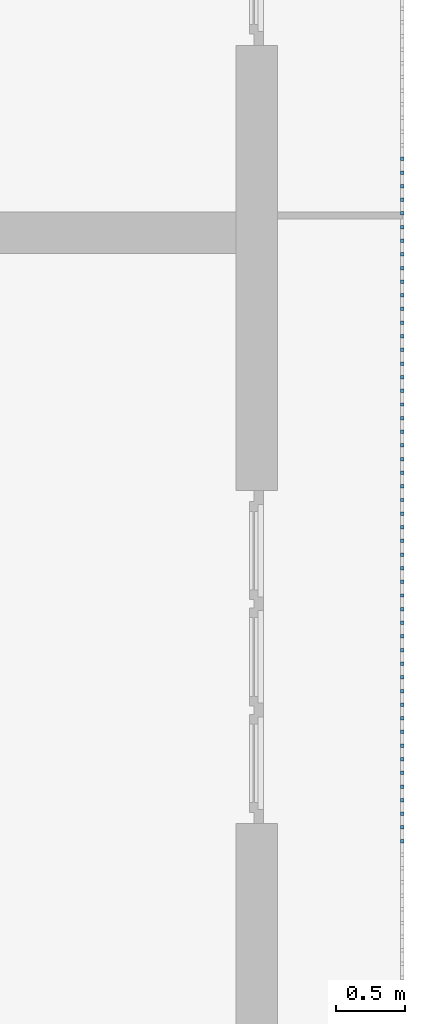
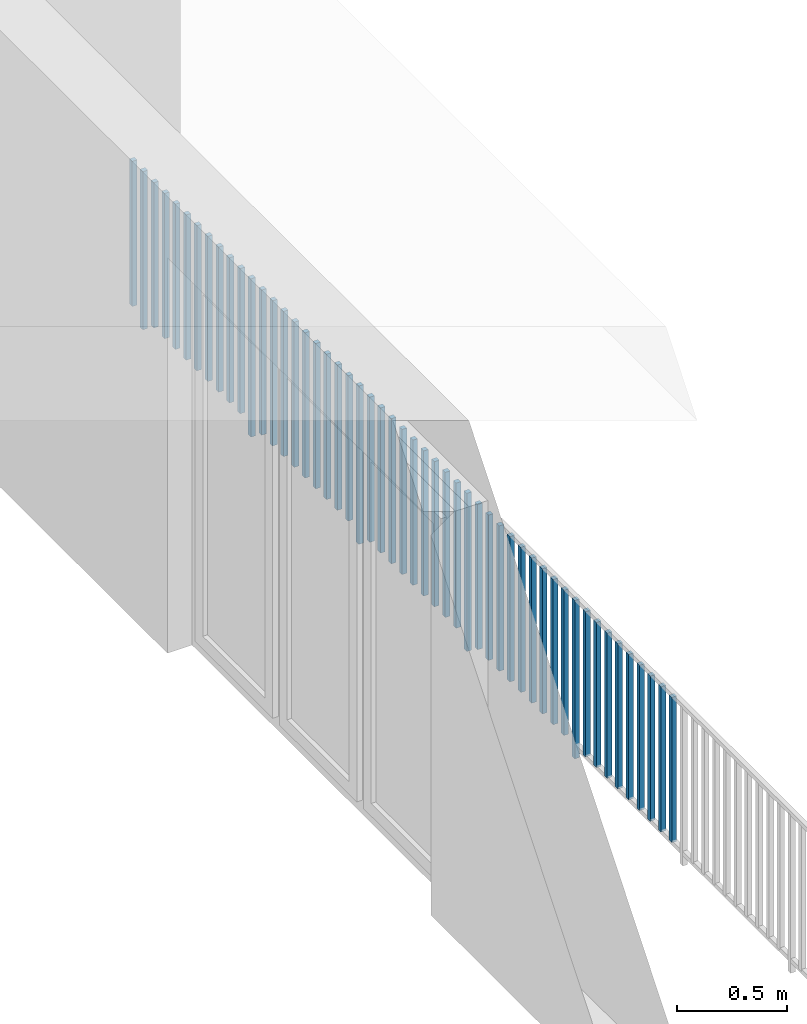
# One storey, part 39 of 48: 51 building element parts, 1 element without a shape of its own.
"""IFC4 building model written with IfcOpenShell, lengths in metres."""

from ifc_helpers import new_model, entity, si_unit, converted_unit, derived_unit, direction, frame, origin_with_axes, place, context, subcontext, project, spatial, polygons, material, type_object, element, aggregate, save


model = new_model("IFC4")

# Units and contexts
model_context = context("Model", 3, precision=1e-05, world=origin_with_axes(), true_north=direction((0.0, 1.0)))
body_context = subcontext(model_context, "Body", "Model", "MODEL_VIEW")
ifc_project = project(units=[si_unit("LENGTHUNIT", "METRE"), si_unit("AREAUNIT", "SQUARE_METRE"), si_unit("VOLUMEUNIT", "CUBIC_METRE"), converted_unit("PLANEANGLEUNIT", "DEGREE", entity("IfcPlaneAngleMeasure", 0.0174532925199), si_unit("PLANEANGLEUNIT", "RADIAN"), dimensions=[0, 0, 0, 0, 0, 0, 0]), converted_unit("TIMEUNIT", "Year", entity("IfcTimeMeasure", 31556926.0), si_unit("TIMEUNIT", "SECOND"), dimensions=[0, 0, 1, 0, 0, 0, 0]), si_unit("MASSUNIT", "GRAM", prefix="KILO"), si_unit("THERMODYNAMICTEMPERATUREUNIT", "DEGREE_CELSIUS"), si_unit("LUMINOUSINTENSITYUNIT", "LUMEN"), si_unit("ENERGYUNIT", "JOULE", prefix="MEGA"), derived_unit("THERMALCONDUCTANCEUNIT", [(si_unit("POWERUNIT", "WATT"), 1), (si_unit("LENGTHUNIT", "METRE"), -1), (si_unit("THERMODYNAMICTEMPERATUREUNIT", "KELVIN"), -1)]), derived_unit("SPECIFICHEATCAPACITYUNIT", [(si_unit("ENERGYUNIT", "JOULE"), 1), (si_unit("MASSUNIT", "GRAM", prefix="KILO"), -1), (si_unit("THERMODYNAMICTEMPERATUREUNIT", "KELVIN"), -1)]), derived_unit("MASSDENSITYUNIT", [(si_unit("MASSUNIT", "GRAM", prefix="KILO"), 1), (si_unit("VOLUMEUNIT", "CUBIC_METRE"), -1)])], contexts=[model_context])

# Site, building, storey
site_placement = place(None, origin_with_axes())
site = spatial("IfcSite", under=ifc_project, at=site_placement, CompositionType="ELEMENT")
building_placement = place(site_placement, origin_with_axes())
building = spatial("IfcBuilding", under=site, at=building_placement, CompositionType="ELEMENT")
storey_placement = place(building_placement, frame((0.0, 0.0, 3.4), z_axis=(0.0, 0.0, 1.0), x_axis=(1.0, 0.0, 0.0)))
storey = spatial("IfcBuildingStorey", under=building, at=storey_placement, Name="1. Geschoss", CompositionType="ELEMENT", Elevation=3.4)

# Railing, building element parts
railing_type = type_object("IfcRailingType", PredefinedType="NOTDEFINED")
railing_placement = place(storey_placement, frame((10.2378006196, 9.82118776896, 0.0), z_axis=(0.0, 0.0, 1.0), x_axis=(1.0, 0.0, 0.0)))
railing = element("IfcRailing", 1, at=railing_placement, inside=storey, type_object=railing_type, PredefinedType="NOTDEFINED")
ifc_material = material()
building_element_part_1_placement = place(railing_placement, origin_with_axes())
building_element_part_1 = element("IfcBuildingElementPart", 2, at=building_element_part_1_placement, material=ifc_material, PredefinedType="NOTDEFINED", context=body_context, shape_type="Tessellation", body=[
    polygons([(0.0125, -12.6725, 0.07), (-0.0125, -12.6725, 0.07), (-0.0125, -12.6725, 0.8775), (0.0125, -12.6725, 0.8775), (0.0125, -12.6975, 0.07), (-0.0125, -12.6975, 0.07), (-0.0125, -12.6975, 0.8775), (0.0125, -12.6975, 0.8775)], [[[1, 2, 3, 4]], [[1, 5, 6, 2]], [[2, 6, 7, 3]], [[4, 3, 7, 8]], [[5, 1, 4, 8]], [[6, 5, 8, 7]]], closed=True),
])
building_element_part_2_placement = place(railing_placement, origin_with_axes())
building_element_part_2 = element("IfcBuildingElementPart", 3, at=building_element_part_2_placement, material=ifc_material, PredefinedType="NOTDEFINED", context=body_context, shape_type="Tessellation", body=[
    polygons([(0.0125, -12.5741666667, 0.07), (-0.0125, -12.5741666667, 0.07), (-0.0125, -12.5741666667, 0.8775), (0.0125, -12.5741666667, 0.8775), (0.0125, -12.5991666667, 0.07), (-0.0125, -12.5991666667, 0.07), (-0.0125, -12.5991666667, 0.8775), (0.0125, -12.5991666667, 0.8775)], [[[1, 2, 3, 4]], [[1, 5, 6, 2]], [[2, 6, 7, 3]], [[4, 3, 7, 8]], [[5, 1, 4, 8]], [[6, 5, 8, 7]]], closed=True),
])
building_element_part_3_placement = place(railing_placement, origin_with_axes())
building_element_part_3 = element("IfcBuildingElementPart", 4, at=building_element_part_3_placement, material=ifc_material, PredefinedType="NOTDEFINED", context=body_context, shape_type="Tessellation", body=[
    polygons([(0.0125, -12.4758333333, 0.07), (-0.0125, -12.4758333333, 0.07), (-0.0125, -12.4758333333, 0.8775), (0.0125, -12.4758333333, 0.8775), (0.0125, -12.5008333333, 0.07), (-0.0125, -12.5008333333, 0.07), (-0.0125, -12.5008333333, 0.8775), (0.0125, -12.5008333333, 0.8775)], [[[1, 2, 3, 4]], [[1, 5, 6, 2]], [[2, 6, 7, 3]], [[4, 3, 7, 8]], [[5, 1, 4, 8]], [[6, 5, 8, 7]]], closed=True),
])
building_element_part_4_placement = place(railing_placement, origin_with_axes())
building_element_part_4 = element("IfcBuildingElementPart", 5, at=building_element_part_4_placement, material=ifc_material, PredefinedType="NOTDEFINED", context=body_context, shape_type="Tessellation", body=[
    polygons([(0.0125, -12.3775, 0.07), (-0.0125, -12.3775, 0.07), (-0.0125, -12.3775, 0.8775), (0.0125, -12.3775, 0.8775), (0.0125, -12.4025, 0.07), (-0.0125, -12.4025, 0.07), (-0.0125, -12.4025, 0.8775), (0.0125, -12.4025, 0.8775)], [[[1, 2, 3, 4]], [[1, 5, 6, 2]], [[2, 6, 7, 3]], [[4, 3, 7, 8]], [[5, 1, 4, 8]], [[6, 5, 8, 7]]], closed=True),
])
building_element_part_5_placement = place(railing_placement, origin_with_axes())
building_element_part_5 = element("IfcBuildingElementPart", 6, at=building_element_part_5_placement, material=ifc_material, PredefinedType="NOTDEFINED", context=body_context, shape_type="Tessellation", body=[
    polygons([(0.0125, -12.2791666667, 0.07), (-0.0125, -12.2791666667, 0.07), (-0.0125, -12.2791666667, 0.8775), (0.0125, -12.2791666667, 0.8775), (0.0125, -12.3041666667, 0.07), (-0.0125, -12.3041666667, 0.07), (-0.0125, -12.3041666667, 0.8775), (0.0125, -12.3041666667, 0.8775)], [[[1, 2, 3, 4]], [[1, 5, 6, 2]], [[2, 6, 7, 3]], [[4, 3, 7, 8]], [[5, 1, 4, 8]], [[6, 5, 8, 7]]], closed=True),
])
building_element_part_6_placement = place(railing_placement, origin_with_axes())
building_element_part_6 = element("IfcBuildingElementPart", 7, at=building_element_part_6_placement, material=ifc_material, PredefinedType="NOTDEFINED", context=body_context, shape_type="Tessellation", body=[
    polygons([(0.0125, -12.1808333333, 0.07), (-0.0125, -12.1808333333, 0.07), (-0.0125, -12.1808333333, 0.8775), (0.0125, -12.1808333333, 0.8775), (0.0125, -12.2058333333, 0.07), (-0.0125, -12.2058333333, 0.07), (-0.0125, -12.2058333333, 0.8775), (0.0125, -12.2058333333, 0.8775)], [[[1, 2, 3, 4]], [[1, 5, 6, 2]], [[2, 6, 7, 3]], [[4, 3, 7, 8]], [[5, 1, 4, 8]], [[6, 5, 8, 7]]], closed=True),
])
building_element_part_7_placement = place(railing_placement, origin_with_axes())
building_element_part_7 = element("IfcBuildingElementPart", 8, at=building_element_part_7_placement, material=ifc_material, PredefinedType="NOTDEFINED", context=body_context, shape_type="Tessellation", body=[
    polygons([(0.0125, -12.0825, 0.07), (-0.0125, -12.0825, 0.07), (-0.0125, -12.0825, 0.8775), (0.0125, -12.0825, 0.8775), (0.0125, -12.1075, 0.07), (-0.0125, -12.1075, 0.07), (-0.0125, -12.1075, 0.8775), (0.0125, -12.1075, 0.8775)], [[[1, 2, 3, 4]], [[1, 5, 6, 2]], [[2, 6, 7, 3]], [[4, 3, 7, 8]], [[5, 1, 4, 8]], [[6, 5, 8, 7]]], closed=True),
])
building_element_part_8_placement = place(railing_placement, origin_with_axes())
building_element_part_8 = element("IfcBuildingElementPart", 9, at=building_element_part_8_placement, material=ifc_material, PredefinedType="NOTDEFINED", context=body_context, shape_type="Tessellation", body=[
    polygons([(0.0125, -11.9841666667, 0.07), (-0.0125, -11.9841666667, 0.07), (-0.0125, -11.9841666667, 0.8775), (0.0125, -11.9841666667, 0.8775), (0.0125, -12.0091666667, 0.07), (-0.0125, -12.0091666667, 0.07), (-0.0125, -12.0091666667, 0.8775), (0.0125, -12.0091666667, 0.8775)], [[[1, 2, 3, 4]], [[1, 5, 6, 2]], [[2, 6, 7, 3]], [[4, 3, 7, 8]], [[5, 1, 4, 8]], [[6, 5, 8, 7]]], closed=True),
])
building_element_part_9_placement = place(railing_placement, origin_with_axes())
building_element_part_9 = element("IfcBuildingElementPart", 10, at=building_element_part_9_placement, material=ifc_material, PredefinedType="NOTDEFINED", context=body_context, shape_type="Tessellation", body=[
    polygons([(0.0125, -11.8858333333, 0.07), (-0.0125, -11.8858333333, 0.07), (-0.0125, -11.8858333333, 0.8775), (0.0125, -11.8858333333, 0.8775), (0.0125, -11.9108333333, 0.07), (-0.0125, -11.9108333333, 0.07), (-0.0125, -11.9108333333, 0.8775), (0.0125, -11.9108333333, 0.8775)], [[[1, 2, 3, 4]], [[1, 5, 6, 2]], [[2, 6, 7, 3]], [[4, 3, 7, 8]], [[5, 1, 4, 8]], [[6, 5, 8, 7]]], closed=True),
])
building_element_part_10_placement = place(railing_placement, origin_with_axes())
building_element_part_10 = element("IfcBuildingElementPart", 11, at=building_element_part_10_placement, material=ifc_material, PredefinedType="NOTDEFINED", context=body_context, shape_type="Tessellation", body=[
    polygons([(0.0125, -11.7875, 0.0), (-0.0125, -11.7875, 0.0), (-0.0125, -11.7875, 0.88), (0.0125, -11.7875, 0.88), (0.0125, -11.8125, 0.0), (-0.0125, -11.8125, 0.0), (-0.0125, -11.8125, 0.88), (0.0125, -11.8125, 0.88)], [[[1, 2, 3, 4]], [[1, 5, 6, 2]], [[2, 6, 7, 3]], [[4, 3, 7, 8]], [[5, 1, 4, 8]], [[6, 5, 8, 7]]], closed=True),
])
building_element_part_11_placement = place(railing_placement, origin_with_axes())
building_element_part_11 = element("IfcBuildingElementPart", 12, at=building_element_part_11_placement, material=ifc_material, PredefinedType="NOTDEFINED", context=body_context, shape_type="Tessellation", body=[
    polygons([(0.0125, -11.6891666667, 0.07), (-0.0125, -11.6891666667, 0.07), (-0.0125, -11.6891666667, 0.8775), (0.0125, -11.6891666667, 0.8775), (0.0125, -11.7141666667, 0.07), (-0.0125, -11.7141666667, 0.07), (-0.0125, -11.7141666667, 0.8775), (0.0125, -11.7141666667, 0.8775)], [[[1, 2, 3, 4]], [[1, 5, 6, 2]], [[2, 6, 7, 3]], [[4, 3, 7, 8]], [[5, 1, 4, 8]], [[6, 5, 8, 7]]], closed=True),
])
building_element_part_12_placement = place(railing_placement, origin_with_axes())
building_element_part_12 = element("IfcBuildingElementPart", 13, at=building_element_part_12_placement, material=ifc_material, PredefinedType="NOTDEFINED", context=body_context, shape_type="Tessellation", body=[
    polygons([(0.0125, -11.5908333333, 0.07), (-0.0125, -11.5908333333, 0.07), (-0.0125, -11.5908333333, 0.8775), (0.0125, -11.5908333333, 0.8775), (0.0125, -11.6158333333, 0.07), (-0.0125, -11.6158333333, 0.07), (-0.0125, -11.6158333333, 0.8775), (0.0125, -11.6158333333, 0.8775)], [[[1, 2, 3, 4]], [[1, 5, 6, 2]], [[2, 6, 7, 3]], [[4, 3, 7, 8]], [[5, 1, 4, 8]], [[6, 5, 8, 7]]], closed=True),
])
building_element_part_13_placement = place(railing_placement, origin_with_axes())
building_element_part_13 = element("IfcBuildingElementPart", 14, at=building_element_part_13_placement, material=ifc_material, PredefinedType="NOTDEFINED", context=body_context, shape_type="Tessellation", body=[
    polygons([(0.0125, -11.4925, 0.07), (-0.0125, -11.4925, 0.07), (-0.0125, -11.4925, 0.8775), (0.0125, -11.4925, 0.8775), (0.0125, -11.5175, 0.07), (-0.0125, -11.5175, 0.07), (-0.0125, -11.5175, 0.8775), (0.0125, -11.5175, 0.8775)], [[[1, 2, 3, 4]], [[1, 5, 6, 2]], [[2, 6, 7, 3]], [[4, 3, 7, 8]], [[5, 1, 4, 8]], [[6, 5, 8, 7]]], closed=True),
])
building_element_part_14_placement = place(railing_placement, origin_with_axes())
building_element_part_14 = element("IfcBuildingElementPart", 15, at=building_element_part_14_placement, material=ifc_material, PredefinedType="NOTDEFINED", context=body_context, shape_type="Tessellation", body=[
    polygons([(0.0125, -11.3941666667, 0.07), (-0.0125, -11.3941666667, 0.07), (-0.0125, -11.3941666667, 0.8775), (0.0125, -11.3941666667, 0.8775), (0.0125, -11.4191666667, 0.07), (-0.0125, -11.4191666667, 0.07), (-0.0125, -11.4191666667, 0.8775), (0.0125, -11.4191666667, 0.8775)], [[[1, 2, 3, 4]], [[1, 5, 6, 2]], [[2, 6, 7, 3]], [[4, 3, 7, 8]], [[5, 1, 4, 8]], [[6, 5, 8, 7]]], closed=True),
])
building_element_part_15_placement = place(railing_placement, origin_with_axes())
building_element_part_15 = element("IfcBuildingElementPart", 16, at=building_element_part_15_placement, material=ifc_material, PredefinedType="NOTDEFINED", context=body_context, shape_type="Tessellation", body=[
    polygons([(0.0125, -11.2958333333, 0.07), (-0.0125, -11.2958333333, 0.07), (-0.0125, -11.2958333333, 0.8775), (0.0125, -11.2958333333, 0.8775), (0.0125, -11.3208333333, 0.07), (-0.0125, -11.3208333333, 0.07), (-0.0125, -11.3208333333, 0.8775), (0.0125, -11.3208333333, 0.8775)], [[[1, 2, 3, 4]], [[1, 5, 6, 2]], [[2, 6, 7, 3]], [[4, 3, 7, 8]], [[5, 1, 4, 8]], [[6, 5, 8, 7]]], closed=True),
])
building_element_part_16_placement = place(railing_placement, origin_with_axes())
building_element_part_16 = element("IfcBuildingElementPart", 17, at=building_element_part_16_placement, material=ifc_material, PredefinedType="NOTDEFINED", context=body_context, shape_type="Tessellation", body=[
    polygons([(0.0125, -11.1975, 0.07), (-0.0125, -11.1975, 0.07), (-0.0125, -11.1975, 0.8775), (0.0125, -11.1975, 0.8775), (0.0125, -11.2225, 0.07), (-0.0125, -11.2225, 0.07), (-0.0125, -11.2225, 0.8775), (0.0125, -11.2225, 0.8775)], [[[1, 2, 3, 4]], [[1, 5, 6, 2]], [[2, 6, 7, 3]], [[4, 3, 7, 8]], [[5, 1, 4, 8]], [[6, 5, 8, 7]]], closed=True),
])
building_element_part_17_placement = place(railing_placement, origin_with_axes())
building_element_part_17 = element("IfcBuildingElementPart", 18, at=building_element_part_17_placement, material=ifc_material, PredefinedType="NOTDEFINED", context=body_context, shape_type="Tessellation", body=[
    polygons([(0.0125, -11.0991666667, 0.07), (-0.0125, -11.0991666667, 0.07), (-0.0125, -11.0991666667, 0.8775), (0.0125, -11.0991666667, 0.8775), (0.0125, -11.1241666667, 0.07), (-0.0125, -11.1241666667, 0.07), (-0.0125, -11.1241666667, 0.8775), (0.0125, -11.1241666667, 0.8775)], [[[1, 2, 3, 4]], [[1, 5, 6, 2]], [[2, 6, 7, 3]], [[4, 3, 7, 8]], [[5, 1, 4, 8]], [[6, 5, 8, 7]]], closed=True),
])
building_element_part_18_placement = place(railing_placement, origin_with_axes())
building_element_part_18 = element("IfcBuildingElementPart", 19, at=building_element_part_18_placement, material=ifc_material, PredefinedType="NOTDEFINED", context=body_context, shape_type="Tessellation", body=[
    polygons([(0.0125, -11.0008333333, 0.07), (-0.0125, -11.0008333333, 0.07), (-0.0125, -11.0008333333, 0.8775), (0.0125, -11.0008333333, 0.8775), (0.0125, -11.0258333333, 0.07), (-0.0125, -11.0258333333, 0.07), (-0.0125, -11.0258333333, 0.8775), (0.0125, -11.0258333333, 0.8775)], [[[1, 2, 3, 4]], [[1, 5, 6, 2]], [[2, 6, 7, 3]], [[4, 3, 7, 8]], [[5, 1, 4, 8]], [[6, 5, 8, 7]]], closed=True),
])
building_element_part_19_placement = place(railing_placement, origin_with_axes())
building_element_part_19 = element("IfcBuildingElementPart", 20, at=building_element_part_19_placement, material=ifc_material, PredefinedType="NOTDEFINED", context=body_context, shape_type="Tessellation", body=[
    polygons([(0.0125, -10.9025, 0.07), (-0.0125, -10.9025, 0.07), (-0.0125, -10.9025, 0.8775), (0.0125, -10.9025, 0.8775), (0.0125, -10.9275, 0.07), (-0.0125, -10.9275, 0.07), (-0.0125, -10.9275, 0.8775), (0.0125, -10.9275, 0.8775)], [[[1, 2, 3, 4]], [[1, 5, 6, 2]], [[2, 6, 7, 3]], [[4, 3, 7, 8]], [[5, 1, 4, 8]], [[6, 5, 8, 7]]], closed=True),
])
building_element_part_20_placement = place(railing_placement, origin_with_axes())
building_element_part_20 = element("IfcBuildingElementPart", 21, at=building_element_part_20_placement, material=ifc_material, PredefinedType="NOTDEFINED", context=body_context, shape_type="Tessellation", body=[
    polygons([(0.0125, -10.8041666667, 0.0), (-0.0125, -10.8041666667, 0.0), (-0.0125, -10.8041666667, 0.88), (0.0125, -10.8041666667, 0.88), (0.0125, -10.8291666667, 0.0), (-0.0125, -10.8291666667, 0.0), (-0.0125, -10.8291666667, 0.88), (0.0125, -10.8291666667, 0.88)], [[[1, 2, 3, 4]], [[1, 5, 6, 2]], [[2, 6, 7, 3]], [[4, 3, 7, 8]], [[5, 1, 4, 8]], [[6, 5, 8, 7]]], closed=True),
])
building_element_part_21_placement = place(railing_placement, origin_with_axes())
building_element_part_21 = element("IfcBuildingElementPart", 22, at=building_element_part_21_placement, material=ifc_material, PredefinedType="NOTDEFINED", context=body_context, shape_type="Tessellation", body=[
    polygons([(0.0125, -10.7058333333, 0.07), (-0.0125, -10.7058333333, 0.07), (-0.0125, -10.7058333333, 0.8775), (0.0125, -10.7058333333, 0.8775), (0.0125, -10.7308333333, 0.07), (-0.0125, -10.7308333333, 0.07), (-0.0125, -10.7308333333, 0.8775), (0.0125, -10.7308333333, 0.8775)], [[[1, 2, 3, 4]], [[1, 5, 6, 2]], [[2, 6, 7, 3]], [[4, 3, 7, 8]], [[5, 1, 4, 8]], [[6, 5, 8, 7]]], closed=True),
])
building_element_part_22_placement = place(railing_placement, origin_with_axes())
building_element_part_22 = element("IfcBuildingElementPart", 23, at=building_element_part_22_placement, material=ifc_material, PredefinedType="NOTDEFINED", context=body_context, shape_type="Tessellation", body=[
    polygons([(0.0125, -10.6075, 0.07), (-0.0125, -10.6075, 0.07), (-0.0125, -10.6075, 0.8775), (0.0125, -10.6075, 0.8775), (0.0125, -10.6325, 0.07), (-0.0125, -10.6325, 0.07), (-0.0125, -10.6325, 0.8775), (0.0125, -10.6325, 0.8775)], [[[1, 2, 3, 4]], [[1, 5, 6, 2]], [[2, 6, 7, 3]], [[4, 3, 7, 8]], [[5, 1, 4, 8]], [[6, 5, 8, 7]]], closed=True),
])
building_element_part_23_placement = place(railing_placement, origin_with_axes())
building_element_part_23 = element("IfcBuildingElementPart", 24, at=building_element_part_23_placement, material=ifc_material, PredefinedType="NOTDEFINED", context=body_context, shape_type="Tessellation", body=[
    polygons([(0.0125, -10.5091666667, 0.07), (-0.0125, -10.5091666667, 0.07), (-0.0125, -10.5091666667, 0.8775), (0.0125, -10.5091666667, 0.8775), (0.0125, -10.5341666667, 0.07), (-0.0125, -10.5341666667, 0.07), (-0.0125, -10.5341666667, 0.8775), (0.0125, -10.5341666667, 0.8775)], [[[1, 2, 3, 4]], [[1, 5, 6, 2]], [[2, 6, 7, 3]], [[4, 3, 7, 8]], [[5, 1, 4, 8]], [[6, 5, 8, 7]]], closed=True),
])
building_element_part_24_placement = place(railing_placement, origin_with_axes())
building_element_part_24 = element("IfcBuildingElementPart", 25, at=building_element_part_24_placement, material=ifc_material, PredefinedType="NOTDEFINED", context=body_context, shape_type="Tessellation", body=[
    polygons([(0.0125, -10.4108333333, 0.07), (-0.0125, -10.4108333333, 0.07), (-0.0125, -10.4108333333, 0.8775), (0.0125, -10.4108333333, 0.8775), (0.0125, -10.4358333333, 0.07), (-0.0125, -10.4358333333, 0.07), (-0.0125, -10.4358333333, 0.8775), (0.0125, -10.4358333333, 0.8775)], [[[1, 2, 3, 4]], [[1, 5, 6, 2]], [[2, 6, 7, 3]], [[4, 3, 7, 8]], [[5, 1, 4, 8]], [[6, 5, 8, 7]]], closed=True),
])
building_element_part_25_placement = place(railing_placement, origin_with_axes())
building_element_part_25 = element("IfcBuildingElementPart", 26, at=building_element_part_25_placement, material=ifc_material, PredefinedType="NOTDEFINED", context=body_context, shape_type="Tessellation", body=[
    polygons([(0.0125, -10.3125, 0.07), (-0.0125, -10.3125, 0.07), (-0.0125, -10.3125, 0.8775), (0.0125, -10.3125, 0.8775), (0.0125, -10.3375, 0.07), (-0.0125, -10.3375, 0.07), (-0.0125, -10.3375, 0.8775), (0.0125, -10.3375, 0.8775)], [[[1, 2, 3, 4]], [[1, 5, 6, 2]], [[2, 6, 7, 3]], [[4, 3, 7, 8]], [[5, 1, 4, 8]], [[6, 5, 8, 7]]], closed=True),
])
building_element_part_26_placement = place(railing_placement, origin_with_axes())
building_element_part_26 = element("IfcBuildingElementPart", 27, at=building_element_part_26_placement, material=ifc_material, PredefinedType="NOTDEFINED", context=body_context, shape_type="Tessellation", body=[
    polygons([(0.0125, -10.2141666667, 0.07), (-0.0125, -10.2141666667, 0.07), (-0.0125, -10.2141666667, 0.8775), (0.0125, -10.2141666667, 0.8775), (0.0125, -10.2391666667, 0.07), (-0.0125, -10.2391666667, 0.07), (-0.0125, -10.2391666667, 0.8775), (0.0125, -10.2391666667, 0.8775)], [[[1, 2, 3, 4]], [[1, 5, 6, 2]], [[2, 6, 7, 3]], [[4, 3, 7, 8]], [[5, 1, 4, 8]], [[6, 5, 8, 7]]], closed=True),
])
building_element_part_27_placement = place(railing_placement, origin_with_axes())
building_element_part_27 = element("IfcBuildingElementPart", 28, at=building_element_part_27_placement, material=ifc_material, PredefinedType="NOTDEFINED", context=body_context, shape_type="Tessellation", body=[
    polygons([(0.0125, -10.1158333333, 0.07), (-0.0125, -10.1158333333, 0.07), (-0.0125, -10.1158333333, 0.8775), (0.0125, -10.1158333333, 0.8775), (0.0125, -10.1408333333, 0.07), (-0.0125, -10.1408333333, 0.07), (-0.0125, -10.1408333333, 0.8775), (0.0125, -10.1408333333, 0.8775)], [[[1, 2, 3, 4]], [[1, 5, 6, 2]], [[2, 6, 7, 3]], [[4, 3, 7, 8]], [[5, 1, 4, 8]], [[6, 5, 8, 7]]], closed=True),
])
building_element_part_28_placement = place(railing_placement, origin_with_axes())
building_element_part_28 = element("IfcBuildingElementPart", 29, at=building_element_part_28_placement, material=ifc_material, PredefinedType="NOTDEFINED", context=body_context, shape_type="Tessellation", body=[
    polygons([(0.0125, -10.0175, 0.07), (-0.0125, -10.0175, 0.07), (-0.0125, -10.0175, 0.8775), (0.0125, -10.0175, 0.8775), (0.0125, -10.0425, 0.07), (-0.0125, -10.0425, 0.07), (-0.0125, -10.0425, 0.8775), (0.0125, -10.0425, 0.8775)], [[[1, 2, 3, 4]], [[1, 5, 6, 2]], [[2, 6, 7, 3]], [[4, 3, 7, 8]], [[5, 1, 4, 8]], [[6, 5, 8, 7]]], closed=True),
])
building_element_part_29_placement = place(railing_placement, origin_with_axes())
building_element_part_29 = element("IfcBuildingElementPart", 30, at=building_element_part_29_placement, material=ifc_material, PredefinedType="NOTDEFINED", context=body_context, shape_type="Tessellation", body=[
    polygons([(0.0125, -9.91916666667, 0.07), (-0.0125, -9.91916666667, 0.07), (-0.0125, -9.91916666667, 0.8775), (0.0125, -9.91916666667, 0.8775), (0.0125, -9.94416666667, 0.07), (-0.0125, -9.94416666667, 0.07), (-0.0125, -9.94416666667, 0.8775), (0.0125, -9.94416666667, 0.8775)], [[[1, 2, 3, 4]], [[1, 5, 6, 2]], [[2, 6, 7, 3]], [[4, 3, 7, 8]], [[5, 1, 4, 8]], [[6, 5, 8, 7]]], closed=True),
])
building_element_part_30_placement = place(railing_placement, origin_with_axes())
building_element_part_30 = element("IfcBuildingElementPart", 31, at=building_element_part_30_placement, material=ifc_material, PredefinedType="NOTDEFINED", context=body_context, shape_type="Tessellation", body=[
    polygons([(0.0125, -9.82083333333, 0.0), (-0.0125, -9.82083333333, 0.0), (-0.0125, -9.82083333333, 0.88), (0.0125, -9.82083333333, 0.88), (0.0125, -9.84583333333, 0.0), (-0.0125, -9.84583333333, 0.0), (-0.0125, -9.84583333333, 0.88), (0.0125, -9.84583333333, 0.88)], [[[1, 2, 3, 4]], [[1, 5, 6, 2]], [[2, 6, 7, 3]], [[4, 3, 7, 8]], [[5, 1, 4, 8]], [[6, 5, 8, 7]]], closed=True),
])
building_element_part_31_placement = place(railing_placement, origin_with_axes())
building_element_part_31 = element("IfcBuildingElementPart", 32, at=building_element_part_31_placement, material=ifc_material, PredefinedType="NOTDEFINED", context=body_context, shape_type="Tessellation", body=[
    polygons([(0.0125, -9.7225, 0.07), (-0.0125, -9.7225, 0.07), (-0.0125, -9.7225, 0.8775), (0.0125, -9.7225, 0.8775), (0.0125, -9.7475, 0.07), (-0.0125, -9.7475, 0.07), (-0.0125, -9.7475, 0.8775), (0.0125, -9.7475, 0.8775)], [[[1, 2, 3, 4]], [[1, 5, 6, 2]], [[2, 6, 7, 3]], [[4, 3, 7, 8]], [[5, 1, 4, 8]], [[6, 5, 8, 7]]], closed=True),
])
building_element_part_32_placement = place(railing_placement, origin_with_axes())
building_element_part_32 = element("IfcBuildingElementPart", 33, at=building_element_part_32_placement, material=ifc_material, PredefinedType="NOTDEFINED", context=body_context, shape_type="Tessellation", body=[
    polygons([(0.0125, -9.62416666667, 0.07), (-0.0125, -9.62416666667, 0.07), (-0.0125, -9.62416666667, 0.8775), (0.0125, -9.62416666667, 0.8775), (0.0125, -9.64916666667, 0.07), (-0.0125, -9.64916666667, 0.07), (-0.0125, -9.64916666667, 0.8775), (0.0125, -9.64916666667, 0.8775)], [[[1, 2, 3, 4]], [[1, 5, 6, 2]], [[2, 6, 7, 3]], [[4, 3, 7, 8]], [[5, 1, 4, 8]], [[6, 5, 8, 7]]], closed=True),
])
building_element_part_33_placement = place(railing_placement, origin_with_axes())
building_element_part_33 = element("IfcBuildingElementPart", 34, at=building_element_part_33_placement, material=ifc_material, PredefinedType="NOTDEFINED", context=body_context, shape_type="Tessellation", body=[
    polygons([(0.0125, -9.52583333333, 0.07), (-0.0125, -9.52583333333, 0.07), (-0.0125, -9.52583333333, 0.8775), (0.0125, -9.52583333333, 0.8775), (0.0125, -9.55083333333, 0.07), (-0.0125, -9.55083333333, 0.07), (-0.0125, -9.55083333333, 0.8775), (0.0125, -9.55083333333, 0.8775)], [[[1, 2, 3, 4]], [[1, 5, 6, 2]], [[2, 6, 7, 3]], [[4, 3, 7, 8]], [[5, 1, 4, 8]], [[6, 5, 8, 7]]], closed=True),
])
building_element_part_34_placement = place(railing_placement, origin_with_axes())
building_element_part_34 = element("IfcBuildingElementPart", 35, at=building_element_part_34_placement, material=ifc_material, PredefinedType="NOTDEFINED", context=body_context, shape_type="Tessellation", body=[
    polygons([(0.0125, -9.4275, 0.07), (-0.0125, -9.4275, 0.07), (-0.0125, -9.4275, 0.8775), (0.0125, -9.4275, 0.8775), (0.0125, -9.4525, 0.07), (-0.0125, -9.4525, 0.07), (-0.0125, -9.4525, 0.8775), (0.0125, -9.4525, 0.8775)], [[[1, 2, 3, 4]], [[1, 5, 6, 2]], [[2, 6, 7, 3]], [[4, 3, 7, 8]], [[5, 1, 4, 8]], [[6, 5, 8, 7]]], closed=True),
])
building_element_part_35_placement = place(railing_placement, origin_with_axes())
building_element_part_35 = element("IfcBuildingElementPart", 36, at=building_element_part_35_placement, material=ifc_material, PredefinedType="NOTDEFINED", context=body_context, shape_type="Tessellation", body=[
    polygons([(0.0125, -9.32916666667, 0.07), (-0.0125, -9.32916666667, 0.07), (-0.0125, -9.32916666667, 0.8775), (0.0125, -9.32916666667, 0.8775), (0.0125, -9.35416666667, 0.07), (-0.0125, -9.35416666667, 0.07), (-0.0125, -9.35416666667, 0.8775), (0.0125, -9.35416666667, 0.8775)], [[[1, 2, 3, 4]], [[1, 5, 6, 2]], [[2, 6, 7, 3]], [[4, 3, 7, 8]], [[5, 1, 4, 8]], [[6, 5, 8, 7]]], closed=True),
])
building_element_part_36_placement = place(railing_placement, origin_with_axes())
building_element_part_36 = element("IfcBuildingElementPart", 37, at=building_element_part_36_placement, material=ifc_material, PredefinedType="NOTDEFINED", context=body_context, shape_type="Tessellation", body=[
    polygons([(0.0125, -9.23083333333, 0.07), (-0.0125, -9.23083333333, 0.07), (-0.0125, -9.23083333333, 0.8775), (0.0125, -9.23083333333, 0.8775), (0.0125, -9.25583333333, 0.07), (-0.0125, -9.25583333333, 0.07), (-0.0125, -9.25583333333, 0.8775), (0.0125, -9.25583333333, 0.8775)], [[[1, 2, 3, 4]], [[1, 5, 6, 2]], [[2, 6, 7, 3]], [[4, 3, 7, 8]], [[5, 1, 4, 8]], [[6, 5, 8, 7]]], closed=True),
])
building_element_part_37_placement = place(railing_placement, origin_with_axes())
building_element_part_37 = element("IfcBuildingElementPart", 38, at=building_element_part_37_placement, material=ifc_material, PredefinedType="NOTDEFINED", context=body_context, shape_type="Tessellation", body=[
    polygons([(0.0125, -9.1325, 0.07), (-0.0125, -9.1325, 0.07), (-0.0125, -9.1325, 0.8775), (0.0125, -9.1325, 0.8775), (0.0125, -9.1575, 0.07), (-0.0125, -9.1575, 0.07), (-0.0125, -9.1575, 0.8775), (0.0125, -9.1575, 0.8775)], [[[1, 2, 3, 4]], [[1, 5, 6, 2]], [[2, 6, 7, 3]], [[4, 3, 7, 8]], [[5, 1, 4, 8]], [[6, 5, 8, 7]]], closed=True),
])
building_element_part_38_placement = place(railing_placement, origin_with_axes())
building_element_part_38 = element("IfcBuildingElementPart", 39, at=building_element_part_38_placement, material=ifc_material, PredefinedType="NOTDEFINED", context=body_context, shape_type="Tessellation", body=[
    polygons([(0.0125, -9.03416666667, 0.07), (-0.0125, -9.03416666667, 0.07), (-0.0125, -9.03416666667, 0.8775), (0.0125, -9.03416666667, 0.8775), (0.0125, -9.05916666667, 0.07), (-0.0125, -9.05916666667, 0.07), (-0.0125, -9.05916666667, 0.8775), (0.0125, -9.05916666667, 0.8775)], [[[1, 2, 3, 4]], [[1, 5, 6, 2]], [[2, 6, 7, 3]], [[4, 3, 7, 8]], [[5, 1, 4, 8]], [[6, 5, 8, 7]]], closed=True),
])
building_element_part_39_placement = place(railing_placement, origin_with_axes())
building_element_part_39 = element("IfcBuildingElementPart", 40, at=building_element_part_39_placement, material=ifc_material, PredefinedType="NOTDEFINED", context=body_context, shape_type="Tessellation", body=[
    polygons([(0.0125, -8.93583333333, 0.07), (-0.0125, -8.93583333333, 0.07), (-0.0125, -8.93583333333, 0.8775), (0.0125, -8.93583333333, 0.8775), (0.0125, -8.96083333333, 0.07), (-0.0125, -8.96083333333, 0.07), (-0.0125, -8.96083333333, 0.8775), (0.0125, -8.96083333333, 0.8775)], [[[1, 2, 3, 4]], [[1, 5, 6, 2]], [[2, 6, 7, 3]], [[4, 3, 7, 8]], [[5, 1, 4, 8]], [[6, 5, 8, 7]]], closed=True),
])
building_element_part_40_placement = place(railing_placement, origin_with_axes())
building_element_part_40 = element("IfcBuildingElementPart", 41, at=building_element_part_40_placement, material=ifc_material, PredefinedType="NOTDEFINED", context=body_context, shape_type="Tessellation", body=[
    polygons([(0.0125, -8.8375, 0.0), (-0.0125, -8.8375, 0.0), (-0.0125, -8.8375, 0.88), (0.0125, -8.8375, 0.88), (0.0125, -8.8625, 0.0), (-0.0125, -8.8625, 0.0), (-0.0125, -8.8625, 0.88), (0.0125, -8.8625, 0.88)], [[[1, 2, 3, 4]], [[1, 5, 6, 2]], [[2, 6, 7, 3]], [[4, 3, 7, 8]], [[5, 1, 4, 8]], [[6, 5, 8, 7]]], closed=True),
])
building_element_part_41_placement = place(railing_placement, origin_with_axes())
building_element_part_41 = element("IfcBuildingElementPart", 42, at=building_element_part_41_placement, material=ifc_material, PredefinedType="NOTDEFINED", context=body_context, shape_type="Tessellation", body=[
    polygons([(0.0125, -8.73916666667, 0.07), (-0.0125, -8.73916666667, 0.07), (-0.0125, -8.73916666667, 0.8775), (0.0125, -8.73916666667, 0.8775), (0.0125, -8.76416666667, 0.07), (-0.0125, -8.76416666667, 0.07), (-0.0125, -8.76416666667, 0.8775), (0.0125, -8.76416666667, 0.8775)], [[[1, 2, 3, 4]], [[1, 5, 6, 2]], [[2, 6, 7, 3]], [[4, 3, 7, 8]], [[5, 1, 4, 8]], [[6, 5, 8, 7]]], closed=True),
])
building_element_part_42_placement = place(railing_placement, origin_with_axes())
building_element_part_42 = element("IfcBuildingElementPart", 43, at=building_element_part_42_placement, material=ifc_material, PredefinedType="NOTDEFINED", context=body_context, shape_type="Tessellation", body=[
    polygons([(0.0125, -8.64083333333, 0.07), (-0.0125, -8.64083333333, 0.07), (-0.0125, -8.64083333333, 0.8775), (0.0125, -8.64083333333, 0.8775), (0.0125, -8.66583333333, 0.07), (-0.0125, -8.66583333333, 0.07), (-0.0125, -8.66583333333, 0.8775), (0.0125, -8.66583333333, 0.8775)], [[[1, 2, 3, 4]], [[1, 5, 6, 2]], [[2, 6, 7, 3]], [[4, 3, 7, 8]], [[5, 1, 4, 8]], [[6, 5, 8, 7]]], closed=True),
])
building_element_part_43_placement = place(railing_placement, origin_with_axes())
building_element_part_43 = element("IfcBuildingElementPart", 44, at=building_element_part_43_placement, material=ifc_material, PredefinedType="NOTDEFINED", context=body_context, shape_type="Tessellation", body=[
    polygons([(0.0125, -8.5425, 0.07), (-0.0125, -8.5425, 0.07), (-0.0125, -8.5425, 0.8775), (0.0125, -8.5425, 0.8775), (0.0125, -8.5675, 0.07), (-0.0125, -8.5675, 0.07), (-0.0125, -8.5675, 0.8775), (0.0125, -8.5675, 0.8775)], [[[1, 2, 3, 4]], [[1, 5, 6, 2]], [[2, 6, 7, 3]], [[4, 3, 7, 8]], [[5, 1, 4, 8]], [[6, 5, 8, 7]]], closed=True),
])
building_element_part_44_placement = place(railing_placement, origin_with_axes())
building_element_part_44 = element("IfcBuildingElementPart", 45, at=building_element_part_44_placement, material=ifc_material, PredefinedType="NOTDEFINED", context=body_context, shape_type="Tessellation", body=[
    polygons([(0.0125, -8.44416666667, 0.07), (-0.0125, -8.44416666667, 0.07), (-0.0125, -8.44416666667, 0.8775), (0.0125, -8.44416666667, 0.8775), (0.0125, -8.46916666667, 0.07), (-0.0125, -8.46916666667, 0.07), (-0.0125, -8.46916666667, 0.8775), (0.0125, -8.46916666667, 0.8775)], [[[1, 2, 3, 4]], [[1, 5, 6, 2]], [[2, 6, 7, 3]], [[4, 3, 7, 8]], [[5, 1, 4, 8]], [[6, 5, 8, 7]]], closed=True),
])
building_element_part_45_placement = place(railing_placement, origin_with_axes())
building_element_part_45 = element("IfcBuildingElementPart", 46, at=building_element_part_45_placement, material=ifc_material, PredefinedType="NOTDEFINED", context=body_context, shape_type="Tessellation", body=[
    polygons([(0.0125, -8.34583333333, 0.07), (-0.0125, -8.34583333333, 0.07), (-0.0125, -8.34583333333, 0.8775), (0.0125, -8.34583333333, 0.8775), (0.0125, -8.37083333333, 0.07), (-0.0125, -8.37083333333, 0.07), (-0.0125, -8.37083333333, 0.8775), (0.0125, -8.37083333333, 0.8775)], [[[1, 2, 3, 4]], [[1, 5, 6, 2]], [[2, 6, 7, 3]], [[4, 3, 7, 8]], [[5, 1, 4, 8]], [[6, 5, 8, 7]]], closed=True),
])
building_element_part_46_placement = place(railing_placement, origin_with_axes())
building_element_part_46 = element("IfcBuildingElementPart", 47, at=building_element_part_46_placement, material=ifc_material, PredefinedType="NOTDEFINED", context=body_context, shape_type="Tessellation", body=[
    polygons([(0.0125, -8.2475, 0.07), (-0.0125, -8.2475, 0.07), (-0.0125, -8.2475, 0.8775), (0.0125, -8.2475, 0.8775), (0.0125, -8.2725, 0.07), (-0.0125, -8.2725, 0.07), (-0.0125, -8.2725, 0.8775), (0.0125, -8.2725, 0.8775)], [[[1, 2, 3, 4]], [[1, 5, 6, 2]], [[2, 6, 7, 3]], [[4, 3, 7, 8]], [[5, 1, 4, 8]], [[6, 5, 8, 7]]], closed=True),
])
building_element_part_47_placement = place(railing_placement, origin_with_axes())
building_element_part_47 = element("IfcBuildingElementPart", 48, at=building_element_part_47_placement, material=ifc_material, PredefinedType="NOTDEFINED", context=body_context, shape_type="Tessellation", body=[
    polygons([(0.0125, -8.14916666667, 0.07), (-0.0125, -8.14916666667, 0.07), (-0.0125, -8.14916666667, 0.8775), (0.0125, -8.14916666667, 0.8775), (0.0125, -8.17416666667, 0.07), (-0.0125, -8.17416666667, 0.07), (-0.0125, -8.17416666667, 0.8775), (0.0125, -8.17416666667, 0.8775)], [[[1, 2, 3, 4]], [[1, 5, 6, 2]], [[2, 6, 7, 3]], [[4, 3, 7, 8]], [[5, 1, 4, 8]], [[6, 5, 8, 7]]], closed=True),
])
building_element_part_48_placement = place(railing_placement, origin_with_axes())
building_element_part_48 = element("IfcBuildingElementPart", 49, at=building_element_part_48_placement, material=ifc_material, PredefinedType="NOTDEFINED", context=body_context, shape_type="Tessellation", body=[
    polygons([(0.0125, -8.05083333333, 0.07), (-0.0125, -8.05083333333, 0.07), (-0.0125, -8.05083333333, 0.8775), (0.0125, -8.05083333333, 0.8775), (0.0125, -8.07583333333, 0.07), (-0.0125, -8.07583333333, 0.07), (-0.0125, -8.07583333333, 0.8775), (0.0125, -8.07583333333, 0.8775)], [[[1, 2, 3, 4]], [[1, 5, 6, 2]], [[2, 6, 7, 3]], [[4, 3, 7, 8]], [[5, 1, 4, 8]], [[6, 5, 8, 7]]], closed=True),
])
building_element_part_49_placement = place(railing_placement, origin_with_axes())
building_element_part_49 = element("IfcBuildingElementPart", 50, at=building_element_part_49_placement, material=ifc_material, PredefinedType="NOTDEFINED", context=body_context, shape_type="Tessellation", body=[
    polygons([(0.0125, -7.9525, 0.07), (-0.0125, -7.9525, 0.07), (-0.0125, -7.9525, 0.8775), (0.0125, -7.9525, 0.8775), (0.0125, -7.9775, 0.07), (-0.0125, -7.9775, 0.07), (-0.0125, -7.9775, 0.8775), (0.0125, -7.9775, 0.8775)], [[[1, 2, 3, 4]], [[1, 5, 6, 2]], [[2, 6, 7, 3]], [[4, 3, 7, 8]], [[5, 1, 4, 8]], [[6, 5, 8, 7]]], closed=True),
])
building_element_part_50_placement = place(railing_placement, origin_with_axes())
building_element_part_50 = element("IfcBuildingElementPart", 51, at=building_element_part_50_placement, material=ifc_material, PredefinedType="NOTDEFINED", context=body_context, shape_type="Tessellation", body=[
    polygons([(0.0125, -7.85416666667, 0.0), (-0.0125, -7.85416666667, 0.0), (-0.0125, -7.85416666667, 0.88), (0.0125, -7.85416666667, 0.88), (0.0125, -7.87916666667, 0.0), (-0.0125, -7.87916666667, 0.0), (-0.0125, -7.87916666667, 0.88), (0.0125, -7.87916666667, 0.88)], [[[1, 2, 3, 4]], [[1, 5, 6, 2]], [[2, 6, 7, 3]], [[4, 3, 7, 8]], [[5, 1, 4, 8]], [[6, 5, 8, 7]]], closed=True),
])
building_element_part_51_placement = place(railing_placement, origin_with_axes())
building_element_part_51 = element("IfcBuildingElementPart", 52, at=building_element_part_51_placement, material=ifc_material, PredefinedType="NOTDEFINED", context=body_context, shape_type="Tessellation", body=[
    polygons([(0.0125, -7.75583333333, 0.07), (-0.0125, -7.75583333333, 0.07), (-0.0125, -7.75583333333, 0.8775), (0.0125, -7.75583333333, 0.8775), (0.0125, -7.78083333333, 0.07), (-0.0125, -7.78083333333, 0.07), (-0.0125, -7.78083333333, 0.8775), (0.0125, -7.78083333333, 0.8775)], [[[1, 2, 3, 4]], [[1, 5, 6, 2]], [[2, 6, 7, 3]], [[4, 3, 7, 8]], [[5, 1, 4, 8]], [[6, 5, 8, 7]]], closed=True),
])
aggregate(railing, [building_element_part_1, building_element_part_2, building_element_part_3, building_element_part_4, building_element_part_5, building_element_part_6, building_element_part_7, building_element_part_8, building_element_part_9, building_element_part_10, building_element_part_11, building_element_part_12, building_element_part_13, building_element_part_14, building_element_part_15, building_element_part_16, building_element_part_17, building_element_part_18, building_element_part_19, building_element_part_20, building_element_part_21, building_element_part_22, building_element_part_23, building_element_part_24, building_element_part_25, building_element_part_26, building_element_part_27, building_element_part_28, building_element_part_29, building_element_part_30, building_element_part_31, building_element_part_32, building_element_part_33, building_element_part_34, building_element_part_35, building_element_part_36, building_element_part_37, building_element_part_38, building_element_part_39, building_element_part_40, building_element_part_41, building_element_part_42, building_element_part_43, building_element_part_44, building_element_part_45, building_element_part_46, building_element_part_47, building_element_part_48, building_element_part_49, building_element_part_50, building_element_part_51])

save(model, "model.ifc")
